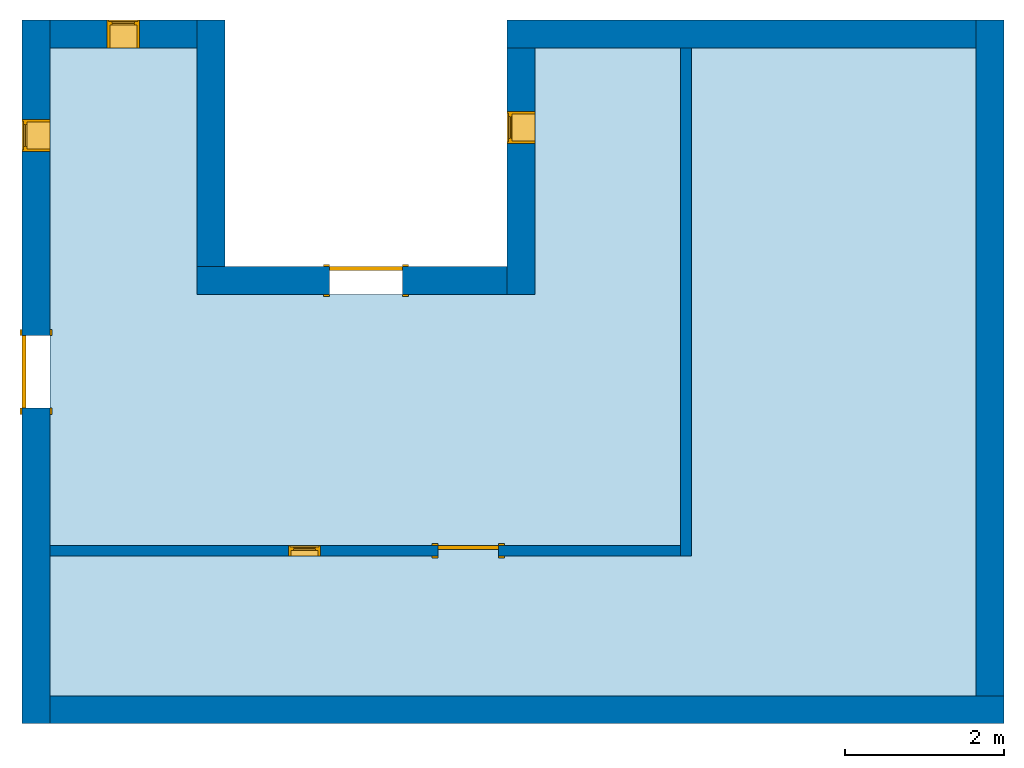
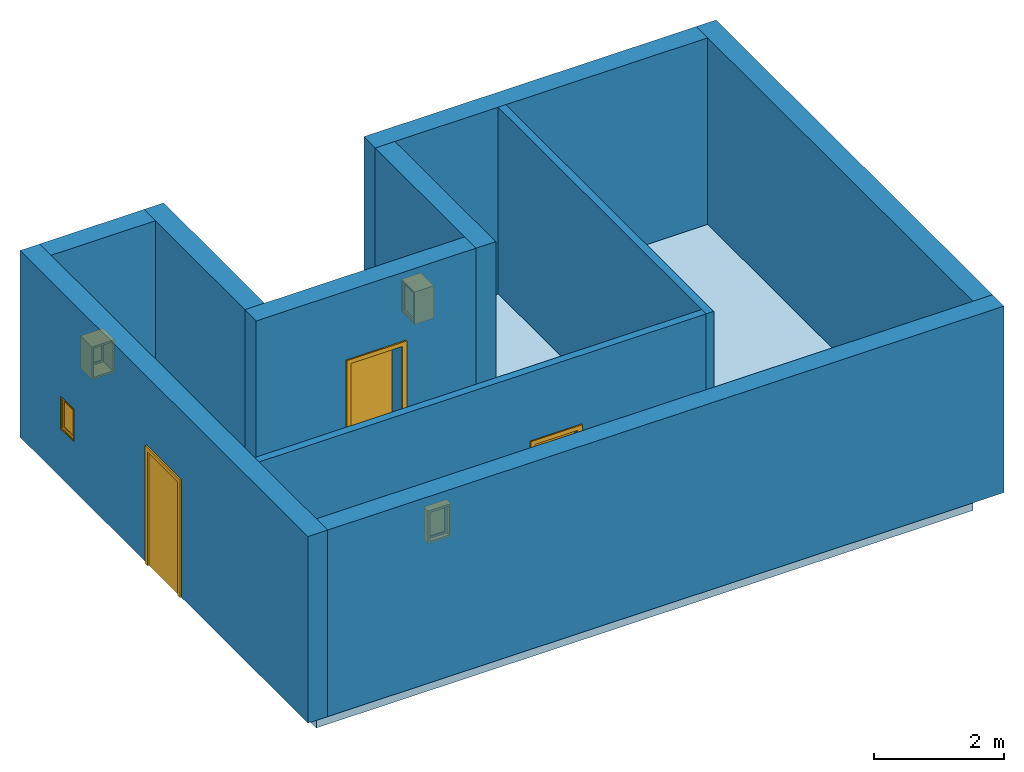
# One storey: 10 walls, 4 windows, 3 doors, 1 slab, 7 openings.
"""IFC4 building model written with IfcOpenShell, lengths in millimetres."""

from ifc_helpers import new_model, entity, si_unit, converted_unit, derived_unit, direction, frame, frame_2d, origin, origin_2d_with_axis, place, context, subcontext, project, spatial, polyline, rectangle, outline, extrude, source, transform, mapped, material, material_list, layer, layer_set, layer_usage, constituent, constituent_set, type_object, type_shapes, element, fill, save


model = new_model("IFC4")

# Units and contexts
model_context = context("Model", 3, precision=0.01, world=origin(), true_north=direction((6.12303176911189e-17, 1.0)))
body_context = subcontext(model_context, "Body", "Model", "MODEL_VIEW")
ifc_project = project(units=[si_unit("LENGTHUNIT", "METRE", prefix="MILLI"), si_unit("AREAUNIT", "SQUARE_METRE"), si_unit("VOLUMEUNIT", "CUBIC_METRE"), converted_unit("PLANEANGLEUNIT", "DEGREE", entity("IfcRatioMeasure", 0.0174532925199433), si_unit("PLANEANGLEUNIT", "RADIAN"), dimensions=[0, 0, 0, 0, 0, 0, 0]), si_unit("MASSUNIT", "GRAM", prefix="KILO"), derived_unit("MASSDENSITYUNIT", [(si_unit("MASSUNIT", "GRAM", prefix="KILO"), 1), (si_unit("LENGTHUNIT", "METRE"), -3)]), derived_unit("MOMENTOFINERTIAUNIT", [(si_unit("LENGTHUNIT", "METRE"), 4)]), si_unit("TIMEUNIT", "SECOND"), si_unit("FREQUENCYUNIT", "HERTZ"), si_unit("THERMODYNAMICTEMPERATUREUNIT", "DEGREE_CELSIUS"), derived_unit("THERMALTRANSMITTANCEUNIT", [(si_unit("MASSUNIT", "GRAM", prefix="KILO"), 1), (si_unit("THERMODYNAMICTEMPERATUREUNIT", "KELVIN"), -1), (si_unit("TIMEUNIT", "SECOND"), -3)]), derived_unit("VOLUMETRICFLOWRATEUNIT", [(si_unit("LENGTHUNIT", "METRE"), 3), (si_unit("TIMEUNIT", "SECOND"), -1)]), si_unit("ELECTRICCURRENTUNIT", "AMPERE"), si_unit("ELECTRICVOLTAGEUNIT", "VOLT"), si_unit("POWERUNIT", "WATT"), si_unit("FORCEUNIT", "NEWTON", prefix="KILO"), si_unit("ILLUMINANCEUNIT", "LUX"), si_unit("LUMINOUSFLUXUNIT", "LUMEN"), si_unit("LUMINOUSINTENSITYUNIT", "CANDELA"), derived_unit("USERDEFINED", [(si_unit("MASSUNIT", "GRAM", prefix="KILO"), -1), (si_unit("LENGTHUNIT", "METRE"), -2), (si_unit("TIMEUNIT", "SECOND"), 3), (si_unit("LUMINOUSFLUXUNIT", "LUMEN"), 1)]), derived_unit("LINEARVELOCITYUNIT", [(si_unit("LENGTHUNIT", "METRE"), 1), (si_unit("TIMEUNIT", "SECOND"), -1)]), si_unit("PRESSUREUNIT", "PASCAL"), derived_unit("USERDEFINED", [(si_unit("LENGTHUNIT", "METRE"), -2), (si_unit("MASSUNIT", "GRAM", prefix="KILO"), 1), (si_unit("TIMEUNIT", "SECOND"), -2)]), derived_unit("LINEARFORCEUNIT", [(si_unit("MASSUNIT", "GRAM", prefix="KILO"), 1), (si_unit("LENGTHUNIT", "METRE"), 1), (si_unit("TIMEUNIT", "SECOND"), -2), (si_unit("LENGTHUNIT", "METRE"), -1)]), derived_unit("PLANARFORCEUNIT", [(si_unit("MASSUNIT", "GRAM", prefix="KILO"), 1), (si_unit("LENGTHUNIT", "METRE"), 1), (si_unit("TIMEUNIT", "SECOND"), -2), (si_unit("LENGTHUNIT", "METRE"), -2)])], contexts=[model_context])

# Site, building, storey
site_placement = place(None, origin())
site = spatial("IfcSite", under=ifc_project, at=site_placement, CompositionType="ELEMENT")
building_placement = place(site_placement, origin())
building = spatial("IfcBuilding", under=site, at=building_placement, CompositionType="ELEMENT")
storey_placement = place(building_placement, origin())
storey = spatial("IfcBuildingStorey", under=building, at=storey_placement, Name="Level 1", CompositionType="ELEMENT", Elevation=0.0)

# Slab
ifc_material_1 = material(Name="Concrete, Sand/Cement Screed", Category="Materials")
ifc_layer_1 = layer(ifc_material_1, 50.0, Name="Concrete, Sand/Cement Screed", Category="Materials")
ifc_material_2 = material(Name="Concrete, Cast In Situ", Category="Materials")
ifc_layer_2 = layer(ifc_material_2, 175.0, Name="Concrete, Cast In Situ", Category="Materials")
ifc_material_3 = material(Name="Damp-proofing", Category="Materials")
ifc_layer_3 = layer(ifc_material_3, 0.0, Name="Damp-proofing", Category="Materials")
ifc_material_4 = material(Name="Rigid insulation", Category="Materials")
ifc_layer_4 = layer(ifc_material_4, 50.0, Name="Rigid insulation", Category="Materials")
ifc_material_5 = material(Name="Site - Hardcore", Category="Materials")
ifc_layer_5 = layer(ifc_material_5, 150.0, Name="Site - Hardcore", Category="Materials")
ifc_layer_set_1 = layer_set([ifc_layer_1, ifc_layer_2, ifc_layer_3, ifc_layer_4, ifc_layer_5], Name="Floor:Concrete-Domestic 425mm")
ifc_layer_usage_1 = layer_usage(ifc_layer_set_1, "AXIS3", "POSITIVE", 0.0)
slab_type = type_object("IfcSlabType", Name="Floor:Concrete-Domestic 425mm", PredefinedType="FLOOR", material=ifc_layer_set_1)
slab_placement = place(storey_placement, origin())
element("IfcSlab", 1, at=slab_placement, inside=storey, type_object=slab_type, material=ifc_layer_usage_1, Name="Floor:Concrete-Domestic 425mm", ObjectType="Floor:Concrete-Domestic 425mm", PredefinedType="FLOOR", context=body_context, shape_type="SweptSolid", body=[
    extrude(outline(polyline([(-5337.49999999999, -4900.0), (2812.50000000001, -4900.0), (2812.5, -3050.0), (-287.500000000007, -3050.0), (-287.5, 1200.0), (2812.5, 1200.0), (2812.49999999999, 6750.0), (-5337.50000000001, 6750.0), (-5337.49999999999, -4900.0)])), frame((-10934.8266444611, 1578.02866926426, 0.0), z_axis=(0.0, 0.0, -1.0), x_axis=(0.0, 1.0, 0.0)), (0.0, 0.0, 1.0), 425.0),
])

# Wall, openings, door, window
ifc_material_6 = material(Name="Brick, Common", Category="Materials")
ifc_layer_6 = layer(ifc_material_6, 90.0, Name="Brick, Common", Category="Materials")
ifc_material_7 = material(Name="Air", Category="Materials")
ifc_layer_7 = layer(ifc_material_7, 76.0, Name="Air", Category="Materials")
ifc_material_8 = material(Name="Air Infiltration Barrier", Category="Materials")
ifc_layer_8 = layer(ifc_material_8, 0.0, Name="Air Infiltration Barrier", Category="Materials")
ifc_material_9 = material(Name="Plywood, Sheathing", Category="Materials")
ifc_layer_9 = layer(ifc_material_9, 19.0, Name="Plywood, Sheathing", Category="Materials")
ifc_material_10 = material(Name="Metal Stud Layer", Category="Materials")
ifc_layer_10 = layer(ifc_material_10, 152.0, Name="Metal Stud Layer", Category="Materials")
ifc_material_11 = material(Name="Vapour Retarder", Category="Materials")
ifc_layer_11 = layer(ifc_material_11, 0.0, Name="Vapour Retarder", Category="Materials")
ifc_material_12 = material(Name="Gypsum Wall Board", Category="Materials")
ifc_layer_12 = layer(ifc_material_12, 13.0, Name="Gypsum Wall Board", Category="Materials")
ifc_layer_set_2 = layer_set([ifc_layer_6, ifc_layer_7, ifc_layer_8, ifc_layer_9, ifc_layer_10, ifc_layer_11, ifc_layer_12], Name="Basic Wall:Exterior - Brick on Mtl. Stud")
ifc_layer_usage_2 = layer_usage(ifc_layer_set_2, "AXIS2", "NEGATIVE", 175.0)
wall_type_1 = type_object("IfcWallType", Name="Basic Wall:Exterior - Brick on Mtl. Stud", PredefinedType="NOTDEFINED", material=ifc_layer_set_2)
wall_1_placement = place(storey_placement, frame((-16009.8266444611, 4740.52866926428, 0.0), z_axis=(0.0, 0.0, 1.0), x_axis=(0.0, -1.0, 0.0)))
wall_1 = element("IfcWall", 2, at=wall_1_placement, inside=storey, type_object=wall_type_1, material=ifc_layer_usage_2, Name="Basic Wall:Exterior - Brick on Mtl. Stud", ObjectType="Basic Wall:Exterior - Brick on Mtl. Stud", PredefinedType="NOTDEFINED", context=body_context, shape_type="SweptSolid", body=[
    extrude(rectangle(XDim=8850.0, YDim=349.999999999998, at=frame_2d((4425.0, 2.8421709430404e-13), x_axis=(-1.0, 0.0))), origin(), (0.0, 0.0, 1.0), 3500.0),
])
opening_1_placement = place(wall_1_placement, frame((4882.5, 175.0, 0.0)))
opening_1 = element("IfcOpeningElement", 3, at=opening_1_placement, cuts=wall_1, Name="M_Single-Flush:0915 x 2134mm:1", ObjectType="Opening", PredefinedType="OPENING", context=body_context, shape_type="SweptSolid", body=[
    extrude(rectangle(XDim=915.0, YDim=2134.0, at=frame_2d((1067.0, 457.5), x_axis=(0.0, 1.0))), frame((0.0, 0.0, 0.0), z_axis=(0.0, -1.0, 0.0), x_axis=(0.0, 0.0, 1.0)), (0.0, 0.0, 1.0), 350.0),
])
opening_2_placement = place(wall_1_placement, frame((1656.0, 175.0, 915.0)))
opening_2 = element("IfcOpeningElement", 4, at=opening_2_placement, cuts=wall_1, Name="M_Fixed:0406 x 0610mm:1", ObjectType="Opening", PredefinedType="OPENING", context=body_context, shape_type="SweptSolid", body=[
    extrude(rectangle(XDim=609.999999999999, YDim=406.0, at=frame_2d((304.999999999999, 203.0), x_axis=(1.0, 0.0))), frame((0.0, 0.0, 0.0), z_axis=(0.0, -1.0, 0.0), x_axis=(0.0, 0.0, 1.0)), (0.0, 0.0, 1.0), 350.0),
])
ifc_material_13 = material(Name="Door - Frame", Category="Materials")
ifc_constituent_1 = constituent(ifc_material_13, Name="Door - Frame", Category="Materials")
ifc_material_14 = material(Name="Door - Panel", Category="Materials")
ifc_constituent_2 = constituent(ifc_material_14, Name="Door - Panel", Category="Materials")
ifc_constituent_set_1 = constituent_set(constituents=[ifc_constituent_1, ifc_constituent_2])
ifc_material_list_1 = material_list([ifc_material_13, ifc_material_14])
door_type_1 = type_object("IfcDoorType", Name="M_Single-Flush:0915 x 2134mm", OperationType="SINGLE_SWING_RIGHT", ParameterTakesPrecedence=False, PredefinedType="DOOR", material=ifc_material_list_1)
shared_shape_1 = source(origin(), body_context, "Body", "SweptSolid", [
    extrude(outline(polyline([(-533.5, -1124.0), (533.5, -1124.0), (533.5, 1086.0), (457.5, 1086.0), (457.5, -1048.0), (-457.5, -1048.0), (-457.5, 1086.0), (-533.5, 1086.0), (-533.5, -1124.0)])), frame((457.500000000001, 350.0, 1086.0), z_axis=(0.0, 1.0, 0.0), x_axis=(1.0, 0.0, 0.0)), (0.0, 0.0, 1.0), 24.9999999999945),
    extrude(outline(polyline([(-1124.0, -533.499999999997), (1086.0, -533.499999999997), (1086.0, -457.500000000007), (-1048.0, -457.500000000007), (-1048.0, 457.500000000002), (1086.0, 457.500000000002), (1086.0, 533.500000000003), (-1124.0, 533.500000000003), (-1124.0, -533.499999999997)])), frame((457.500000000003, -25.0, 1086.0), z_axis=(0.0, 1.0, 0.0), x_axis=(0.0, 0.0, -1.0)), (0.0, 0.0, 1.0), 25.0000000000056),
    extrude(rectangle(XDim=51.0, YDim=915.0, at=frame_2d((1.77635683940025e-14, 0.0), x_axis=(1.0, 0.0))), frame((457.5, 324.500000000001, 0.0), z_axis=(0.0, 0.0, 1.0), x_axis=(0.0, 1.0, 0.0)), (0.0, 0.0, 1.0), 2134.0),
])
type_shapes(door_type_1, [shared_shape_1])
door_1_placement = place(opening_1_placement, frame((0.0, 0.0, 0.0), z_axis=(0.0, 0.0, 1.0), x_axis=(-1.0, 0.0, 0.0)))
door_1 = element("IfcDoor", 5, at=door_1_placement, inside=storey, type_object=door_type_1, material=ifc_constituent_set_1, Name="M_Single-Flush:0915 x 2134mm", ObjectType="M_Single-Flush:0915 x 2134mm", OperationType="SINGLE_SWING_RIGHT", OverallHeight=2134.0, OverallWidth=915.0, PredefinedType="DOOR", context=body_context, shape_type="MappedRepresentation", body=[
    mapped(shared_shape_1, transform((0.0, 0.0, 0.0), scale=1.0)),
])
fill(opening_1, door_1)
ifc_material_15 = material(Name="Glass", Category="Materials")
ifc_constituent_3 = constituent(ifc_material_15, Name="Glass", Category="Materials")
ifc_material_16 = material(Name="Sash", Category="Materials")
ifc_constituent_4 = constituent(ifc_material_16, Name="Sash", Category="Materials")
ifc_constituent_set_2 = constituent_set(constituents=[ifc_constituent_3, ifc_constituent_4])
ifc_material_list_2 = material_list([ifc_material_16, ifc_material_16, ifc_material_16, ifc_material_15])
window_type_1 = type_object("IfcWindowType", Name="M_Fixed:0406 x 0610mm", ParameterTakesPrecedence=False, PartitioningType="NOTDEFINED", PredefinedType="WINDOW", material=ifc_material_list_2)
shared_shape_2 = source(origin(), body_context, "Body", "SweptSolid", [
    extrude(rectangle(XDim=12.0, YDim=279.999999999997, at=frame_2d((8.43769498715119e-15, 0.0), x_axis=(1.0, 0.0))), frame((203.0, 309.0, 63.0), z_axis=(0.0, 0.0, 1.0), x_axis=(0.0, -1.0, 0.0)), (0.0, 0.0, 1.0), 484.000000000008),
    extrude(outline(polyline([(-184.0, -286.0), (184.0, -286.0), (184.0, 286.0), (-184.0, 286.0), (-184.0, -286.0)]), holes=[polyline([(-140.0, -242.0), (-140.0, 242.0), (140.0, 242.0), (140.0, -242.0), (-140.0, -242.0)])]), frame((203.0, 287.0, 305.0), z_axis=(0.0, 1.0, 0.0), x_axis=(1.0, 0.0, 0.0)), (0.0, 0.0, 1.0), 44.0000000000274),
    extrude(outline(polyline([(-203.0, -305.0), (203.0, -305.0), (203.0, 305.0), (-203.0, 305.0), (-203.0, -305.0)]), holes=[polyline([(-184.0, -286.0), (-184.0, 286.0), (184.0, 286.0), (184.0, -286.0), (-184.0, -286.0)])]), frame((203.0, 287.0, 305.0), z_axis=(0.0, 1.0, 0.0), x_axis=(1.0, 0.0, 0.0)), (0.0, 0.0, 1.0), 63.0000000000275),
    extrude(outline(polyline([(-203.0, -305.0), (203.0, -305.0), (203.0, 305.0), (-203.0, 305.0), (-203.0, -305.0)]), holes=[polyline([(-171.0, -273.0), (-171.0, 273.0), (171.0, 273.0), (171.0, -273.0), (-171.0, -273.0)])]), frame((203.0, 0.0, 305.0), z_axis=(0.0, 1.0, 0.0), x_axis=(1.0, 0.0, 0.0)), (0.0, 0.0, 1.0), 286.999999999973),
])
type_shapes(window_type_1, [shared_shape_2])
window_1_placement = place(opening_2_placement, frame((0.0, 0.0, 0.0), z_axis=(0.0, 0.0, 1.0), x_axis=(-1.0, 0.0, 0.0)))
window_1 = element("IfcWindow", 6, at=window_1_placement, inside=storey, type_object=window_type_1, material=ifc_constituent_set_2, Name="M_Fixed:0406 x 0610mm", ObjectType="M_Fixed:0406 x 0610mm", OverallHeight=609.999999999999, OverallWidth=406.0, PartitioningType="NOTDEFINED", PredefinedType="WINDOW", context=body_context, shape_type="MappedRepresentation", body=[
    mapped(shared_shape_2, transform((0.0, 0.0, 0.0), scale=1.0)),
])
fill(opening_2, window_1)

# Walls
ifc_layer_usage_3 = layer_usage(ifc_layer_set_2, "AXIS2", "NEGATIVE", 175.0)
wall_2_placement = place(storey_placement, frame((-15834.8266444612, -3934.47133073572, 0.0)))
element("IfcWall", 7, at=wall_2_placement, inside=storey, type_object=wall_type_1, material=ifc_layer_usage_3, Name="Basic Wall:Exterior - Brick on Mtl. Stud", ObjectType="Basic Wall:Exterior - Brick on Mtl. Stud", PredefinedType="NOTDEFINED", context=body_context, shape_type="SweptSolid", body=[
    extrude(rectangle(XDim=12000.0, YDim=350.000000000001, at=frame_2d((6000.0, -2.8421709430404e-14), x_axis=(-1.0, 0.0))), origin(), (0.0, 0.0, 1.0), 3500.0),
])
ifc_layer_usage_4 = layer_usage(ifc_layer_set_2, "AXIS2", "NEGATIVE", 175.0)
wall_3_placement = place(storey_placement, frame((-4009.82664446115, -3759.47133073575, 0.0), z_axis=(0.0, 0.0, 1.0), x_axis=(0.0, 1.0, 0.0)))
element("IfcWall", 8, at=wall_3_placement, inside=storey, type_object=wall_type_1, material=ifc_layer_usage_4, Name="Basic Wall:Exterior - Brick on Mtl. Stud", ObjectType="Basic Wall:Exterior - Brick on Mtl. Stud", PredefinedType="NOTDEFINED", context=body_context, shape_type="SweptSolid", body=[
    extrude(rectangle(XDim=8500.0, YDim=350.000000000001, at=frame_2d((4250.0, 0.0), x_axis=(-1.0, 0.0))), origin(), (0.0, 0.0, 1.0), 3500.0),
])
ifc_layer_usage_5 = layer_usage(ifc_layer_set_2, "AXIS2", "NEGATIVE", 175.0)
wall_4_placement = place(storey_placement, frame((-4184.82664446114, 4565.52866926425, 0.0), z_axis=(0.0, 0.0, 1.0), x_axis=(-1.0, 0.0, 0.0)))
element("IfcWall", 9, at=wall_4_placement, inside=storey, type_object=wall_type_1, material=ifc_layer_usage_5, Name="Basic Wall:Exterior - Brick on Mtl. Stud", ObjectType="Basic Wall:Exterior - Brick on Mtl. Stud", PredefinedType="NOTDEFINED", context=body_context, shape_type="SweptSolid", body=[
    extrude(rectangle(XDim=5900.0, YDim=350.000000000001, at=frame_2d((2950.0, -5.6843418860808e-14), x_axis=(-1.0, 0.0))), origin(), (0.0, 0.0, 1.0), 3500.0),
])

# Wall, opening, window
ifc_layer_usage_6 = layer_usage(ifc_layer_set_2, "AXIS2", "NEGATIVE", 175.0)
wall_5_placement = place(storey_placement, frame((-9909.82664446114, 4390.52866926426, 0.0), z_axis=(0.0, 0.0, 1.0), x_axis=(0.0, -1.0, 0.0)))
wall_5 = element("IfcWall", 10, at=wall_5_placement, inside=storey, type_object=wall_type_1, material=ifc_layer_usage_6, Name="Basic Wall:Exterior - Brick on Mtl. Stud", ObjectType="Basic Wall:Exterior - Brick on Mtl. Stud", PredefinedType="NOTDEFINED", context=body_context, shape_type="SweptSolid", body=[
    extrude(rectangle(XDim=3100.0, YDim=349.999999999999, at=frame_2d((1550.0, 5.40012479177676e-13), x_axis=(-1.0, 0.0))), origin(), (0.0, 0.0, 1.0), 3500.0),
])
opening_3_placement = place(wall_5_placement, frame((1206.0, 175.0, 915.0)))
opening_3 = element("IfcOpeningElement", 11, at=opening_3_placement, cuts=wall_5, Name="M_Fixed:0406 x 0610mm:1", ObjectType="Opening", PredefinedType="OPENING", context=body_context, shape_type="SweptSolid", body=[
    extrude(rectangle(XDim=609.999999999999, YDim=406.0, at=frame_2d((304.999999999999, 203.0), x_axis=(1.0, 0.0))), frame((0.0, 0.0, 0.0), z_axis=(0.0, -1.0, 0.0), x_axis=(0.0, 0.0, 1.0)), (0.0, 0.0, 1.0), 350.0),
])
ifc_constituent_5 = constituent(ifc_material_15, Name="Glass", Category="Materials")
ifc_constituent_6 = constituent(ifc_material_16, Name="Sash", Category="Materials")
ifc_constituent_set_3 = constituent_set(constituents=[ifc_constituent_5, ifc_constituent_6])
ifc_material_list_3 = material_list([ifc_material_16, ifc_material_15, ifc_material_16, ifc_material_16])
window_type_2 = type_object("IfcWindowType", Name="M_Fixed:0406 x 0610mm", ParameterTakesPrecedence=False, PartitioningType="NOTDEFINED", PredefinedType="WINDOW", material=ifc_material_list_3)
shared_shape_3 = source(origin(), body_context, "Body", "SweptSolid", [
    extrude(rectangle(XDim=279.999999999997, YDim=12.0, at=frame_2d((0.0, 8.43769498715119e-15), x_axis=(1.0, 0.0))), frame((203.0, 335.0, 63.0), z_axis=(0.0, 0.0, 1.0), x_axis=(-1.0, 0.0, 0.0)), (0.0, 0.0, 1.0), 484.000000000008),
    extrude(outline(polyline([(-184.0, -286.0), (184.0, -286.0), (184.0, 286.0), (-184.0, 286.0), (-184.0, -286.0)]), holes=[polyline([(-140.0, -242.0), (-140.0, 242.0), (140.0, 242.0), (140.0, -242.0), (-140.0, -242.0)])]), frame((203.0, 357.0, 305.0), z_axis=(0.0, -1.0, 0.0), x_axis=(-1.0, 0.0, 0.0)), (0.0, 0.0, 1.0), 44.0000000000274),
    extrude(outline(polyline([(-203.0, -305.0), (203.0, -305.0), (203.0, 305.0), (-203.0, 305.0), (-203.0, -305.0)]), holes=[polyline([(-184.0, -286.0), (-184.0, 286.0), (184.0, 286.0), (184.0, -286.0), (-184.0, -286.0)])]), frame((203.0, 376.0, 305.0), z_axis=(0.0, -1.0, 0.0), x_axis=(-1.0, 0.0, 0.0)), (0.0, 0.0, 1.0), 63.0000000000275),
    extrude(outline(polyline([(-203.0, -305.0), (203.0, -305.0), (203.0, 305.0), (-203.0, 305.0), (-203.0, -305.0)]), holes=[polyline([(-171.0, -273.0), (-171.0, 273.0), (171.0, 273.0), (171.0, -273.0), (-171.0, -273.0)])]), frame((203.0, 313.0, 305.0), z_axis=(0.0, -1.0, 0.0), x_axis=(-1.0, 0.0, 0.0)), (0.0, 0.0, 1.0), 286.999999999973),
])
type_shapes(window_type_2, [shared_shape_3])
window_2_placement = place(opening_3_placement, frame((0.0, 26.0, 0.0), z_axis=(0.0, 0.0, 1.0), x_axis=(-1.0, 0.0, 0.0)))
window_2 = element("IfcWindow", 12, at=window_2_placement, inside=storey, type_object=window_type_2, material=ifc_constituent_set_3, Name="M_Fixed:0406 x 0610mm", ObjectType="M_Fixed:0406 x 0610mm", OverallHeight=609.999999999999, OverallWidth=406.0, PartitioningType="NOTDEFINED", PredefinedType="WINDOW", context=body_context, shape_type="MappedRepresentation", body=[
    mapped(shared_shape_3, transform((0.0, 0.0, 0.0), scale=1.0)),
])
fill(opening_3, window_2)

# Wall, opening, door
ifc_layer_usage_7 = layer_usage(ifc_layer_set_2, "AXIS2", "NEGATIVE", 175.0)
wall_6_placement = place(storey_placement, frame((-10084.8266444611, 1465.52866926426, 0.0), z_axis=(0.0, 0.0, 1.0), x_axis=(-1.0, 0.0, 0.0)))
wall_6 = element("IfcWall", 13, at=wall_6_placement, inside=storey, type_object=wall_type_1, material=ifc_layer_usage_7, Name="Basic Wall:Exterior - Brick on Mtl. Stud", ObjectType="Basic Wall:Exterior - Brick on Mtl. Stud", PredefinedType="NOTDEFINED", context=body_context, shape_type="SweptSolid", body=[
    extrude(rectangle(XDim=3900.0, YDim=350.0, at=frame_2d((1950.0, 0.0), x_axis=(-1.0, 0.0))), origin(), (0.0, 0.0, 1.0), 3500.0),
])
opening_4_placement = place(wall_6_placement, frame((2232.5, 175.0, 0.0)))
opening_4 = element("IfcOpeningElement", 14, at=opening_4_placement, cuts=wall_6, Name="M_Single-Flush:0915 x 2134mm:1", ObjectType="Opening", PredefinedType="OPENING", context=body_context, shape_type="SweptSolid", body=[
    extrude(rectangle(XDim=915.0, YDim=2134.0, at=frame_2d((1067.0, 457.5), x_axis=(0.0, 1.0))), frame((0.0, 0.0, 0.0), z_axis=(0.0, -1.0, 0.0), x_axis=(0.0, 0.0, 1.0)), (0.0, 0.0, 1.0), 350.0),
])
ifc_constituent_7 = constituent(ifc_material_13, Name="Door - Frame", Category="Materials")
ifc_constituent_8 = constituent(ifc_material_14, Name="Door - Panel", Category="Materials")
ifc_constituent_set_4 = constituent_set(constituents=[ifc_constituent_7, ifc_constituent_8])
door_2_placement = place(opening_4_placement, frame((0.0, 0.0, 0.0), z_axis=(0.0, 0.0, 1.0), x_axis=(-1.0, 0.0, 0.0)))
door_2 = element("IfcDoor", 15, at=door_2_placement, inside=storey, type_object=door_type_1, material=ifc_constituent_set_4, Name="M_Single-Flush:0915 x 2134mm", ObjectType="M_Single-Flush:0915 x 2134mm", OperationType="SINGLE_SWING_RIGHT", OverallHeight=2134.0, OverallWidth=915.0, PredefinedType="DOOR", context=body_context, shape_type="MappedRepresentation", body=[
    mapped(shared_shape_1, transform((0.0, 0.0, 0.0), scale=1.0)),
])
fill(opening_4, door_2)

# Wall
ifc_layer_usage_8 = layer_usage(ifc_layer_set_2, "AXIS2", "NEGATIVE", 175.0)
wall_7_placement = place(storey_placement, frame((-13809.8266444611, 1640.52866926426, 0.0), z_axis=(0.0, 0.0, 1.0), x_axis=(0.0, 1.0, 0.0)))
element("IfcWall", 16, at=wall_7_placement, inside=storey, type_object=wall_type_1, material=ifc_layer_usage_8, Name="Basic Wall:Exterior - Brick on Mtl. Stud", ObjectType="Basic Wall:Exterior - Brick on Mtl. Stud", PredefinedType="NOTDEFINED", context=body_context, shape_type="SweptSolid", body=[
    extrude(rectangle(XDim=3100.00000000001, YDim=349.999999999998, at=frame_2d((1550.00000000001, 0.0), x_axis=(-1.0, 0.0))), origin(), (0.0, 0.0, 1.0), 3500.0),
])

# Wall, opening, window
ifc_layer_usage_9 = layer_usage(ifc_layer_set_2, "AXIS2", "NEGATIVE", 175.0)
wall_8_placement = place(storey_placement, frame((-13984.8266444611, 4565.52866926427, 0.0), z_axis=(0.0, 0.0, 1.0), x_axis=(-1.0, 0.0, 0.0)))
wall_8 = element("IfcWall", 17, at=wall_8_placement, inside=storey, type_object=wall_type_1, material=ifc_layer_usage_9, Name="Basic Wall:Exterior - Brick on Mtl. Stud", ObjectType="Basic Wall:Exterior - Brick on Mtl. Stud", PredefinedType="NOTDEFINED", context=body_context, shape_type="SweptSolid", body=[
    extrude(rectangle(XDim=1850.00000000001, YDim=350.000000000001, at=frame_2d((925.000000000004, -1.4210854715202e-14), x_axis=(-1.0, 0.0))), origin(), (0.0, 0.0, 1.0), 3500.0),
])
opening_5_placement = place(wall_8_placement, frame((1128.0, 175.0, 915.0)))
opening_5 = element("IfcOpeningElement", 18, at=opening_5_placement, cuts=wall_8, Name="M_Fixed:0406 x 0610mm:1", ObjectType="Opening", PredefinedType="OPENING", context=body_context, shape_type="SweptSolid", body=[
    extrude(rectangle(XDim=609.999999999999, YDim=406.0, at=frame_2d((304.999999999999, 203.0), x_axis=(1.0, 0.0))), frame((0.0, 0.0, 0.0), z_axis=(0.0, -1.0, 0.0), x_axis=(0.0, 0.0, 1.0)), (0.0, 0.0, 1.0), 350.0),
])
ifc_constituent_9 = constituent(ifc_material_15, Name="Glass", Category="Materials")
ifc_constituent_10 = constituent(ifc_material_16, Name="Sash", Category="Materials")
ifc_constituent_set_5 = constituent_set(constituents=[ifc_constituent_9, ifc_constituent_10])
window_3_placement = place(opening_5_placement, frame((0.0, 0.0, 0.0), z_axis=(0.0, 0.0, 1.0), x_axis=(-1.0, 0.0, 0.0)))
window_3 = element("IfcWindow", 19, at=window_3_placement, inside=storey, type_object=window_type_1, material=ifc_constituent_set_5, Name="M_Fixed:0406 x 0610mm", ObjectType="M_Fixed:0406 x 0610mm", OverallHeight=609.999999999999, OverallWidth=405.999999999999, PartitioningType="NOTDEFINED", PredefinedType="WINDOW", context=body_context, shape_type="MappedRepresentation", body=[
    mapped(shared_shape_2, transform((0.0, 0.0, 0.0), scale=1.0)),
])
fill(opening_5, window_3)

# Wall
ifc_layer_13 = layer(ifc_material_12, 15.5, Name="Gypsum Wall Board", Category="Materials")
ifc_layer_14 = layer(ifc_material_12, 15.5, Name="Gypsum Wall Board", Category="Materials")
ifc_layer_15 = layer(ifc_material_10, 64.0, Name="Metal Stud Layer", Category="Materials")
ifc_layer_16 = layer(ifc_material_12, 15.5, Name="Gypsum Wall Board", Category="Materials")
ifc_layer_17 = layer(ifc_material_12, 15.5, Name="Gypsum Wall Board", Category="Materials")
ifc_layer_18 = layer(ifc_material_12, 9.5, Name="Gypsum Wall Board", Category="Materials")
ifc_layer_set_3 = layer_set([ifc_layer_13, ifc_layer_14, ifc_layer_15, ifc_layer_16, ifc_layer_17, ifc_layer_18], Name="Basic Wall:Interior - 135mm Partition (2-hr)")
ifc_layer_usage_10 = layer_usage(ifc_layer_set_3, "AXIS2", "NEGATIVE", 67.75)
wall_type_2 = type_object("IfcWallType", Name="Basic Wall:Interior - 135mm Partition (2-hr)", PredefinedType="NOTDEFINED", material=ifc_layer_set_3)
wall_9_placement = place(storey_placement, frame((-7834.82664446114, 4390.52866926426, 0.0), z_axis=(0.0, 0.0, 1.0), x_axis=(0.0, -1.0, 0.0)))
element("IfcWall", 20, at=wall_9_placement, inside=storey, type_object=wall_type_2, material=ifc_layer_usage_10, Name="Basic Wall:Interior - 135mm Partition (2-hr)", ObjectType="Basic Wall:Interior - 135mm Partition (2-hr)", PredefinedType="NOTDEFINED", context=body_context, shape_type="SweptSolid", body=[
    extrude(rectangle(XDim=6392.75, YDim=135.5, at=frame_2d((3196.375, -1.06581410364015e-13), x_axis=(-1.0, 0.0))), origin(), (0.0, 0.0, 1.0), 3500.0),
])

# Wall, openings, window, door
ifc_layer_usage_11 = layer_usage(ifc_layer_set_3, "AXIS2", "NEGATIVE", 67.75)
wall_10_placement = place(storey_placement, frame((-7902.57664446115, -1934.47133073574, 0.0), z_axis=(0.0, 0.0, 1.0), x_axis=(-1.0, 0.0, 0.0)))
wall_10 = element("IfcWall", 21, at=wall_10_placement, inside=storey, type_object=wall_type_2, material=ifc_layer_usage_11, Name="Basic Wall:Interior - 135mm Partition (2-hr)", ObjectType="Basic Wall:Interior - 135mm Partition (2-hr)", PredefinedType="NOTDEFINED", context=body_context, shape_type="SweptSolid", body=[
    extrude(rectangle(XDim=7932.25000000001, YDim=135.5, at=frame_2d((3966.125, 1.4210854715202e-14), x_axis=(-1.0, 0.0))), origin(), (0.0, 0.0, 1.0), 3500.0),
])
opening_6_placement = place(wall_10_placement, frame((3049.75000000001, 67.7499999999909, 0.0)))
opening_6 = element("IfcOpeningElement", 22, at=opening_6_placement, cuts=wall_10, Name="M_Single-Flush:0762 x 2134mm:1", ObjectType="Opening", PredefinedType="OPENING", context=body_context, shape_type="SweptSolid", body=[
    extrude(rectangle(XDim=762.0, YDim=2134.0, at=frame_2d((1067.0, 381.0), x_axis=(0.0, 1.0))), frame((0.0, 0.0, 0.0), z_axis=(0.0, -1.0, 0.0), x_axis=(0.0, 0.0, 1.0)), (0.0, 0.0, 1.0), 135.5),
])
opening_7_placement = place(wall_10_placement, frame((4932.25000000001, 67.7499999999835, 915.0)))
opening_7 = element("IfcOpeningElement", 23, at=opening_7_placement, cuts=wall_10, Name="M_Fixed:0406 x 0610mm:1", ObjectType="Opening", PredefinedType="OPENING", context=body_context, shape_type="SweptSolid", body=[
    extrude(rectangle(XDim=609.999999999999, YDim=406.0, at=frame_2d((304.999999999999, 203.000000000001), x_axis=(1.0, 0.0))), frame((0.0, 0.0, 0.0), z_axis=(0.0, -1.0, 0.0), x_axis=(0.0, 0.0, 1.0)), (0.0, 0.0, 1.0), 135.5),
])
ifc_constituent_11 = constituent(ifc_material_15, Name="Glass", Category="Materials")
ifc_constituent_12 = constituent(ifc_material_16, Name="Sash", Category="Materials")
ifc_constituent_set_6 = constituent_set(constituents=[ifc_constituent_11, ifc_constituent_12])
ifc_material_list_4 = material_list([ifc_material_16, ifc_material_15, ifc_material_16, ifc_material_16])
window_type_3 = type_object("IfcWindowType", Name="M_Fixed:0406 x 0610mm", ParameterTakesPrecedence=False, PartitioningType="NOTDEFINED", PredefinedType="WINDOW", material=ifc_material_list_4)
shared_shape_4 = source(origin(), body_context, "Body", "SweptSolid", [
    extrude(rectangle(XDim=12.0, YDim=279.999999999997, at=origin_2d_with_axis()), frame((203.0, 94.5000000000006, 63.0), z_axis=(0.0, 0.0, 1.0), x_axis=(0.0, -1.0, 0.0)), (0.0, 0.0, 1.0), 484.000000000008),
    extrude(outline(polyline([(-184.0, -286.0), (184.0, -286.0), (184.0, 286.0), (-184.0, 286.0), (-184.0, -286.0)]), holes=[polyline([(-140.0, -242.0), (-140.0, 242.0), (140.0, 242.0), (140.0, -242.0), (-140.0, -242.0)])]), frame((203.0, 72.4999999999732, 305.0), z_axis=(0.0, 1.0, 0.0), x_axis=(1.0, 0.0, 0.0)), (0.0, 0.0, 1.0), 44.0000000000274),
    extrude(outline(polyline([(-203.0, -305.0), (203.0, -305.0), (203.0, 305.0), (-203.0, 305.0), (-203.0, -305.0)]), holes=[polyline([(-184.0, -286.0), (-184.0, 286.0), (184.0, 286.0), (184.0, -286.0), (-184.0, -286.0)])]), frame((203.0, 72.4999999999732, 305.0), z_axis=(0.0, 1.0, 0.0), x_axis=(1.0, 0.0, 0.0)), (0.0, 0.0, 1.0), 63.0000000000274),
    extrude(outline(polyline([(-203.0, -305.0), (203.0, -305.0), (203.0, 305.0), (-203.0, 305.0), (-203.0, -305.0)]), holes=[polyline([(-171.0, -273.0), (-171.0, 273.0), (171.0, 273.0), (171.0, -273.0), (-171.0, -273.0)])]), frame((203.0, 0.0, 305.0), z_axis=(0.0, 1.0, 0.0), x_axis=(1.0, 0.0, 0.0)), (0.0, 0.0, 1.0), 72.4999999999726),
])
type_shapes(window_type_3, [shared_shape_4])
window_4_placement = place(opening_7_placement, frame((0.0, 0.0, 0.0), z_axis=(0.0, 0.0, 1.0), x_axis=(-1.0, 0.0, 0.0)))
window_4 = element("IfcWindow", 24, at=window_4_placement, inside=storey, type_object=window_type_3, material=ifc_constituent_set_6, Name="M_Fixed:0406 x 0610mm", ObjectType="M_Fixed:0406 x 0610mm", OverallHeight=609.999999999999, OverallWidth=406.000000000001, PartitioningType="NOTDEFINED", PredefinedType="WINDOW", context=body_context, shape_type="MappedRepresentation", body=[
    mapped(shared_shape_4, transform((0.0, 0.0, 0.0), scale=1.0)),
])
fill(opening_7, window_4)
ifc_constituent_13 = constituent(ifc_material_13, Name="Door - Frame", Category="Materials")
ifc_constituent_14 = constituent(ifc_material_14, Name="Door - Panel", Category="Materials")
ifc_constituent_set_7 = constituent_set(constituents=[ifc_constituent_13, ifc_constituent_14])
ifc_material_list_5 = material_list([ifc_material_14, ifc_material_13])
door_type_2 = type_object("IfcDoorType", Name="M_Single-Flush:0762 x 2134mm", OperationType="SINGLE_SWING_RIGHT", ParameterTakesPrecedence=False, PredefinedType="DOOR", material=ifc_material_list_5)
shared_shape_5 = source(origin(), body_context, "Body", "SweptSolid", [
    extrude(outline(polyline([(-457.0, -1124.0), (457.0, -1124.0), (457.0, 1086.0), (381.0, 1086.0), (381.0, -1048.0), (-381.0, -1048.0), (-381.0, 1086.0), (-457.0, 1086.0), (-457.0, -1124.0)])), frame((381.0, 135.500000000001, 1086.0), z_axis=(0.0, 1.0, 0.0), x_axis=(1.0, 0.0, 0.0)), (0.0, 0.0, 1.0), 24.9999999999945),
    extrude(outline(polyline([(-1124.0, -457.0), (1086.0, -457.0), (1086.0, -381.0), (-1048.0, -381.0), (-1048.0, 381.0), (1086.0, 381.0), (1086.0, 457.0), (-1124.0, 457.0), (-1124.0, -457.0)])), frame((381.0, -25.0, 1086.0), z_axis=(0.0, 1.0, 0.0), x_axis=(0.0, 0.0, -1.0)), (0.0, 0.0, 1.0), 25.0000000000056),
    extrude(rectangle(XDim=51.0, YDim=762.0, at=frame_2d((-5.32907051820075e-15, 0.0), x_axis=(1.0, 0.0))), frame((381.0, 110.0, 0.0), z_axis=(0.0, 0.0, 1.0), x_axis=(0.0, 1.0, 0.0)), (0.0, 0.0, 1.0), 2134.0),
])
type_shapes(door_type_2, [shared_shape_5])
door_3_placement = place(opening_6_placement, frame((0.0, 0.0, 0.0), z_axis=(0.0, 0.0, 1.0), x_axis=(-1.0, 0.0, 0.0)))
door_3 = element("IfcDoor", 25, at=door_3_placement, inside=storey, type_object=door_type_2, material=ifc_constituent_set_7, Name="M_Single-Flush:0762 x 2134mm", ObjectType="M_Single-Flush:0762 x 2134mm", OperationType="SINGLE_SWING_RIGHT", OverallHeight=2134.0, OverallWidth=762.0, PredefinedType="DOOR", context=body_context, shape_type="MappedRepresentation", body=[
    mapped(shared_shape_5, transform((0.0, 0.0, 0.0), scale=1.0)),
])
fill(opening_6, door_3)

save(model, "model.ifc")
